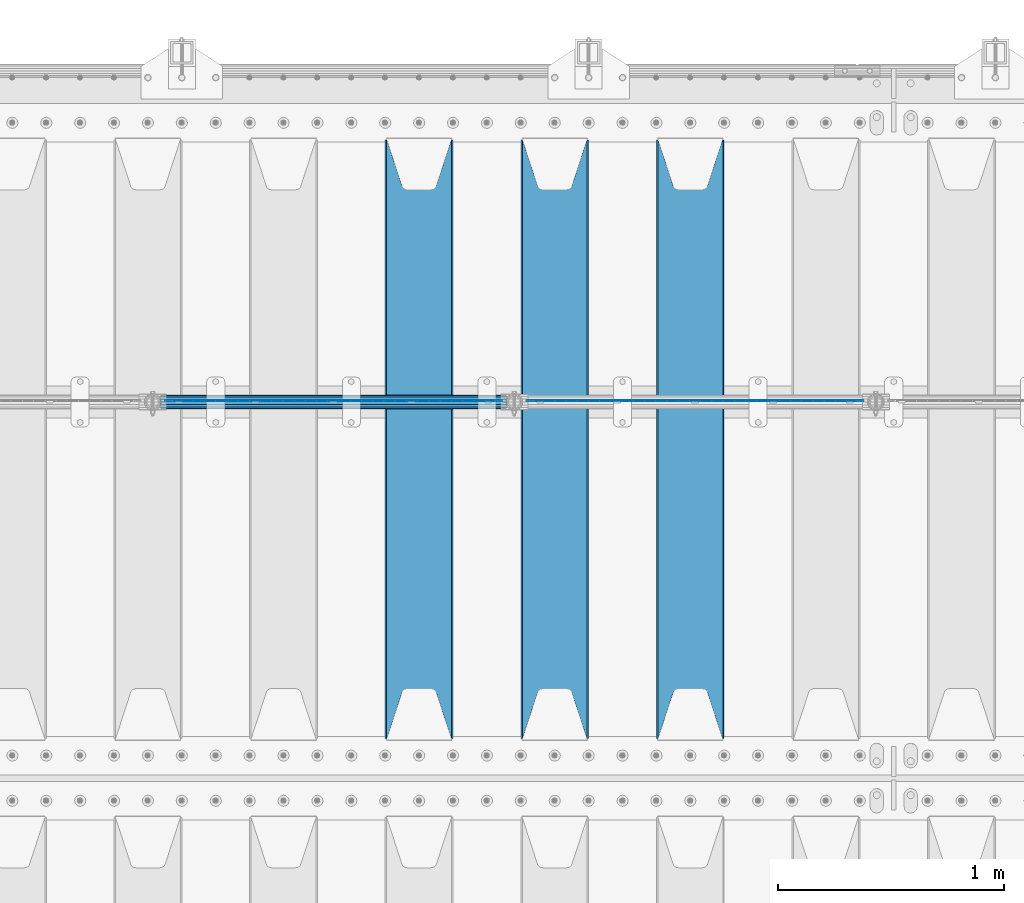
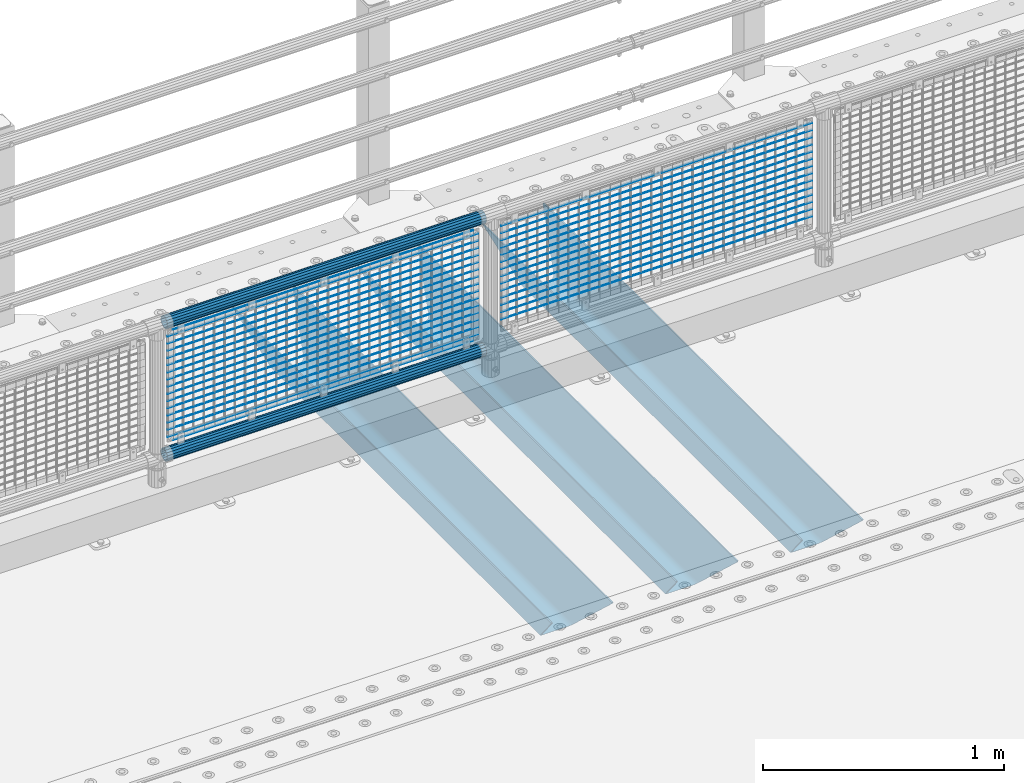
# One storey, part 95 of 208: 36 beams.
"""IFC2X3 building model written with IfcOpenShell, lengths in millimetres."""

import ifcopenshell
import ifcopenshell.guid

model = None  # the IFC model being written
_history = None  # IfcOwnerHistory: only IFC2X3 demands one
_inside = {}  # id of a spatial element -> (the spatial element, [elements in it])
_under = {}  # id of a project, library or spatial element -> (it, [spatial elements below it])
_declared = {}  # id of a project -> (the project, [libraries it declares])
_typed = {}  # id of a type object -> (the type object, [elements of that type])
_made_of = {}  # id of a material, layer set ... -> (it, [elements and type objects made of it])


def new_model(schema):
    """Start an empty IFC model of exactly this schema.

    Asked for "IFC4X3", IfcOpenShell would pick the latest addendum, in which some entities
    have other attributes; the version numbers below select the first issue.
    IFC2X3 requires an IfcOwnerHistory on every rooted entity: one is made here for all.
    """
    global model, _history
    if schema == "IFC4X3":
        model = ifcopenshell.file(schema_version=(4, 3, 0, 0))
    else:
        model = ifcopenshell.file(schema=schema)
    _inside.clear()
    _under.clear()
    _declared.clear()
    _typed.clear()
    _made_of.clear()
    _history = None
    if model.schema == "IFC2X3":
        org = make("IfcOrganization", Name="unknown")
        user = make(
            "IfcPersonAndOrganization",
            ThePerson=make("IfcPerson", FamilyName="unknown"),
            TheOrganization=org,
        )
        app = make(
            "IfcApplication",
            ApplicationDeveloper=org,
            Version="unknown",
            ApplicationFullName="unknown",
            ApplicationIdentifier="unknown",
        )
        _history = make(
            "IfcOwnerHistory",
            OwningUser=user,
            OwningApplication=app,
            ChangeAction="ADDED",
            CreationDate=0,
        )
    return model


def make(cls, **values):
    """One entity of the class cls with the attributes given. An attribute that is None is left unset."""
    return model.create_entity(
        cls, **{name: value for name, value in values.items() if value is not None}
    )


def rooted(cls, **values):
    """An entity with a GlobalId (a new one), such as an element, a storey or a relation."""
    return make(cls, GlobalId=ifcopenshell.guid.new(), OwnerHistory=_history, **values)


def si_unit(unit_type, name, prefix=None):
    """IfcSIUnit, for example si_unit("LENGTHUNIT", "METRE", prefix="MILLI")."""
    return make("IfcSIUnit", UnitType=unit_type, Prefix=prefix, Name=name)


def assignment(units):
    """IfcUnitAssignment: the units of a project."""
    return None if units is None else make("IfcUnitAssignment", Units=units)


def point(xyz):
    """IfcCartesianPoint."""
    return None if xyz is None else make("IfcCartesianPoint", Coordinates=xyz)


def direction(xyz):
    """IfcDirection."""
    return None if xyz is None else make("IfcDirection", DirectionRatios=xyz)


def frame(location, z_axis=None, x_axis=None):
    """IfcAxis2Placement3D, a coordinate frame: its origin and axes. An axis left out is left unset."""
    return make(
        "IfcAxis2Placement3D",
        Location=point(location),
        Axis=direction(z_axis),
        RefDirection=direction(x_axis),
    )


def origin_with_axes():
    """The frame at (0, 0, 0) with the z axis (0, 0, 1) and the x axis (1, 0, 0) written out."""
    return frame((0.0, 0.0, 0.0), z_axis=(0.0, 0.0, 1.0), x_axis=(1.0, 0.0, 0.0))


def place(relative_to, where):
    """IfcLocalPlacement: puts the frame where relative to a parent placement (None: the world)."""
    return make(
        "IfcLocalPlacement", PlacementRelTo=relative_to, RelativePlacement=where
    )


def context(
    kind, dimensions, precision=None, world=None, true_north=None, identifier=None
):
    """IfcGeometricRepresentationContext, for example the 3D "Model" context."""
    return make(
        "IfcGeometricRepresentationContext",
        ContextIdentifier=identifier,
        ContextType=kind,
        CoordinateSpaceDimension=dimensions,
        Precision=precision,
        WorldCoordinateSystem=world,
        TrueNorth=true_north,
    )


def subcontext(parent, identifier, kind, view, scale=None):
    """IfcGeometricRepresentationSubContext, for example "Body" below "Model"."""
    return make(
        "IfcGeometricRepresentationSubContext",
        ContextIdentifier=identifier,
        ContextType=kind,
        ParentContext=parent,
        TargetScale=scale,
        TargetView=view,
    )


def project(units=None, contexts=None):
    """IfcProject with its units and contexts."""
    return rooted(
        "IfcProject",
        Name="project",
        RepresentationContexts=contexts,
        UnitsInContext=assignment(units),
    )


def spatial(cls, under=None, at=None, **own):
    """A site, building, storey or space (cls), placed at a placement, below another one or the project."""
    s = rooted(cls, ObjectPlacement=at, **own)
    if under is not None:
        _under.setdefault(under.id(), (under, []))[1].append(s)
    return s


def faces_of(points, faces, orient=None, outer=None):
    """IfcFace entities. A face is a list of loops; a loop is a list of indices into points, from 0.

    orient and outer hold one flag for each loop. By default every Orientation is true, the
    first loop of a face is its IfcFaceOuterBound and the others are IfcFaceBound.
    """
    made = []
    for i, loops in enumerate(faces):
        bounds = []
        for j, loop in enumerate(loops):
            is_outer = j == 0 if outer is None else outer[i][j]
            bounds.append(
                make(
                    "IfcFaceOuterBound" if is_outer else "IfcFaceBound",
                    Bound=make("IfcPolyLoop", Polygon=[points[k] for k in loop]),
                    Orientation=True if orient is None else orient[i][j],
                )
            )
        made.append(make("IfcFace", Bounds=bounds))
    return made


def faceted_brep(points, faces, orient=None, outer=None, voids=None):
    """IfcFacetedBrep: a solid bounded by flat faces; with voids (closed shells), ...WithVoids."""
    shared = [point(p) for p in points]
    hull = make("IfcClosedShell", CfsFaces=faces_of(shared, faces, orient, outer))
    if voids is None:
        return make("IfcFacetedBrep", Outer=hull)
    return make(
        "IfcFacetedBrepWithVoids",
        Outer=hull,
        Voids=[
            make(cls, CfsFaces=faces_of(shared, fs, o, b)) for cls, fs, o, b in voids
        ],
    )


def shape(context_of_items, identifier, shape_type, items):
    """IfcShapeRepresentation: the items that make up one representation, for example the "Body"."""
    return make(
        "IfcShapeRepresentation",
        ContextOfItems=context_of_items,
        RepresentationIdentifier=identifier,
        RepresentationType=shape_type,
        Items=items,
    )


def material(Name=None, Category=None):
    """IfcMaterial."""
    return make("IfcMaterial", Name=Name, Category=Category)


def made_of(thing, what):
    """Note that an element or type object is made of a material, layer set ...; save() writes the relation."""
    if what is not None:
        _made_of.setdefault(what.id(), (what, []))[1].append(thing)
    return thing


def type_object(cls, material=None, **own):
    """A type object (cls), such as IfcWallType, which elements share."""
    return made_of(rooted(cls, **own), material)


def element(
    cls,
    number,
    at=None,
    inside=None,
    cuts=None,
    type_object=None,
    material=None,
    context=None,
    identifier="Body",
    shape_type=None,
    held_by="IfcProductDefinitionShape",
    body=None,
    shapes=None,
    **own,
):
    """One element of the class cls, such as IfcWall. Its Tag is "e" and its number.

    at: its placement. inside: the storey or other place that contains it. cuts: it is an
    opening in that element (IfcRelVoidsElement). A single representation is given by context,
    identifier, shape_type and body (its items); several are given by shapes. held_by: the class
    of the entity that holds the representations. save() writes the other relations.
    """
    e = rooted(cls, Tag="e%d" % number, ObjectPlacement=at, **own)
    if body is not None:
        shapes = [shape(context, identifier, shape_type, body)]
    if shapes is not None:
        e.Representation = make(held_by, Representations=shapes)
    if inside is not None:
        _inside.setdefault(inside.id(), (inside, []))[1].append(e)
    if cuts is not None:
        rooted(
            "IfcRelVoidsElement", RelatingBuildingElement=cuts, RelatedOpeningElement=e
        )
    if type_object is not None:
        _typed.setdefault(type_object.id(), (type_object, []))[1].append(e)
    return made_of(e, material)


def aggregate(whole, parts):
    """IfcRelAggregates: a whole, such as a stair, and the parts it consists of."""
    return rooted("IfcRelAggregates", RelatingObject=whole, RelatedObjects=parts)


def save(model, path):
    """Write the relations noted so far, then the file.

    IfcRelAggregates (storeys below a building ...), IfcRelContainedInSpatialStructure (elements
    in a storey), IfcRelDefinesByType, IfcRelAssociatesMaterial and IfcRelDeclares: one each for
    every whole, place, type object, material and project.
    """
    for whole, parts in _under.values():
        aggregate(whole, parts)
    for where, things in _inside.values():
        rooted(
            "IfcRelContainedInSpatialStructure",
            RelatedElements=things,
            RelatingStructure=where,
        )
    for kind, things in _typed.values():
        rooted("IfcRelDefinesByType", RelatedObjects=things, RelatingType=kind)
    for what, things in _made_of.values():
        rooted("IfcRelAssociatesMaterial", RelatedObjects=things, RelatingMaterial=what)
    for by, libraries in _declared.values():
        rooted("IfcRelDeclares", RelatingContext=by, RelatedDefinitions=libraries)
    model.write(path)


model = new_model("IFC2X3")

# Units and contexts
model_context = context("Model", 3, precision=1e-05, world=origin_with_axes())
body_context = subcontext(model_context, "Body", "Model", "MODEL_VIEW")
ifc_project = project(units=[si_unit("LENGTHUNIT", "METRE", prefix="MILLI"), si_unit("AREAUNIT", "SQUARE_METRE"), si_unit("VOLUMEUNIT", "CUBIC_METRE"), si_unit("MASSUNIT", "GRAM", prefix="KILO"), si_unit("TIMEUNIT", "SECOND"), si_unit("PLANEANGLEUNIT", "RADIAN"), si_unit("SOLIDANGLEUNIT", "STERADIAN"), si_unit("THERMODYNAMICTEMPERATUREUNIT", "DEGREE_CELSIUS"), si_unit("LUMINOUSINTENSITYUNIT", "LUMEN")], contexts=[model_context])

# Site, building, storey
site_placement = place(None, origin_with_axes())
site = spatial("IfcSite", under=ifc_project, at=site_placement, CompositionType="ELEMENT")
building_placement = place(site_placement, origin_with_axes())
building = spatial("IfcBuilding", under=site, at=building_placement, Name="Standard", CompositionType="ELEMENT")
storey_placement = place(building_placement, origin_with_axes())
storey = spatial("IfcBuildingStorey", under=building, at=storey_placement, Name="Undefined", CompositionType="ELEMENT", Elevation=0.0)

# Beams
ifc_material_1 = material(Name="STEEL/S355N")
beam_type_1 = type_object("IfcBeamType", PredefinedType="NOTDEFINED")
beam_1_placement = place(storey_placement, frame((-37850.0, 3175.0, -115.0), z_axis=(0.0, 0.0, 1.0), x_axis=(0.0, 1.0, 0.0)))
element("IfcBeam", 1, at=beam_1_placement, inside=storey, type_object=beam_type_1, material=ifc_material_1, context=body_context, shape_type="Brep", body=[
    faceted_brep([(0.0, 150.0, 115.0), (0.0, 143.689999999999, 115.0), (2650.00000000297, 143.689999999999, 115.0), (2650.00000000297, 150.0, 115.0), (2650.00000000297, 142.059565218402, 110.0000000031), (2650.00000000297, 148.369565218403, 110.0000000031), (2441.90079219208, -80.1103600731112, -98.0992078077845), (2437.7588105432, -77.5672621345584, -102.241189456673), (2434.06523489746, -74.4080125315522, -105.934765102404), (2430.91086095089, -70.710272125576, -109.089139048974), (2428.37322971128, -66.5649389910068, -111.626770288588), (2426.51472138055, -62.0739139532889, -113.485278619323), (2425.38102192091, -57.3475956567672, -114.618978078955), (2424.99999999987, -52.5021667386536, -115.0), (2424.99999999987, 52.5021667386536, -115.0), (2425.38102192091, 57.3475956567672, -114.618978078955), (2426.51472138055, 62.0739139532889, -113.485278619323), (2428.37322971128, 66.5649389910068, -111.626770288588), (2430.91086095089, 70.710272125576, -109.089139048974), (2434.06523489746, 74.4080125315522, -105.934765102404), (2437.7588105432, 77.5672621345584, -102.241189456673), (2441.90079219208, 80.1103600731112, -98.0992078077846), (2446.38936140511, 81.9747917625791, -93.6106385947584), (2448.24948500409, 76.2713538057251, -91.7505149957729), (2444.62967112262, 74.76777986261, -95.3703288772456), (2441.28936334126, 72.7168944282894, -98.710636658607), (2438.31067330438, 70.1691124903846, -101.689326695487), (2435.76682334747, 67.1870637758839, -104.233176652398), (2433.72034654133, 63.8440531834895, -106.279653458539), (2432.22154950041, 60.222258798236, -107.778450499454), (2431.30727574265, 56.4107117849089, -108.692724257221), (2430.99999999987, 52.5031078186876, -109.0), (2430.99999999987, -52.5031078186876, -109.0), (2431.30727574265, -56.4107117849089, -108.692724257221), (2432.22154950041, -60.222258798236, -107.778450499454), (2433.72034654133, -63.8440531834895, -106.279653458539), (2435.76682334747, -67.1870637758839, -104.233176652398), (2438.31067330438, -70.1691124903846, -101.689326695487), (2441.28936334126, -72.7168944282894, -98.7106366586071), (2444.62967112262, -74.76777986261, -95.3703288772457), (2448.24948500409, -76.2713538057251, -91.7505149957729), (2650.00000000297, -142.059565218402, 110.0000000031), (2650.00000000297, -148.369565218403, 110.0000000031), (2446.38936140511, -81.9747917625791, -93.6106385947584), (2650.00000000297, -143.689999999999, 115.0), (2650.00000000297, -150.0, 115.0), (0.0, -143.689999999999, 115.0), (0.0, -150.0, 115.0), (0.0, -148.369565218261, 110.000000002663), (203.610638597421, -81.9747917625791, -93.6106385947584), (208.099207810448, -80.1103600731112, -98.0992078077845), (212.241189459336, -77.5672621345584, -102.241189456673), (215.934765105067, -74.4080125315522, -105.934765102404), (219.089139051637, -70.710272125576, -109.089139048974), (221.626770291251, -66.5649389910068, -111.626770288588), (223.485278621986, -62.0739139532889, -113.485278619323), (224.618978081618, -57.3475956567672, -114.618978078955), (225.000000002663, -52.5021667386536, -115.0), (225.000000002663, 52.5021667386536, -115.0), (224.618978081618, 57.3475956567672, -114.618978078955), (223.485278621986, 62.0739139532889, -113.485278619323), (221.626770291251, 66.5649389910068, -111.626770288588), (219.089139051637, 70.710272125576, -109.089139048974), (215.934765105067, 74.4080125315522, -105.934765102404), (212.241189459336, 77.5672621345584, -102.241189456673), (208.099207810448, 80.1103600731112, -98.0992078077846), (203.610638597421, 81.9747917625791, -93.6106385947584), (0.0, 148.369565218261, 110.000000002663), (0.0, 142.05956521826, 110.000000002663), (201.750514998436, 76.2713538057251, -91.7505149957729), (205.370328879908, 74.76777986261, -95.3703288772456), (208.71063666127, 72.7168944282894, -98.710636658607), (211.68932669815, 70.1691124903846, -101.689326695487), (214.233176655061, 67.1870637758839, -104.233176652398), (216.279653461202, 63.8440531834895, -106.279653458539), (217.778450502116, 60.222258798236, -107.778450499454), (218.692724259884, 56.4107117849089, -108.692724257221), (219.000000002663, 52.5031078186876, -109.0), (219.000000002663, -52.5031078186876, -109.0), (218.692724259884, -56.4107117849089, -108.692724257221), (217.778450502116, -60.222258798236, -107.778450499454), (216.279653461202, -63.8440531834895, -106.279653458539), (214.233176655061, -67.1870637758839, -104.233176652398), (211.68932669815, -70.1691124903846, -101.689326695487), (208.71063666127, -72.7168944282894, -98.7106366586071), (205.370328879908, -74.76777986261, -95.3703288772457), (201.750514998436, -76.2713538057251, -91.7505149957729), (0.0, -142.05956521826, 110.000000002663)], [[[0, 1, 2, 3]], [[3, 2, 4, 5]], [[6, 7, 8, 9, 10, 11, 12, 13, 14, 15, 16, 17, 18, 19, 20, 21, 22, 5, 4, 23, 24, 25, 26, 27, 28, 29, 30, 31, 32, 33, 34, 35, 36, 37, 38, 39, 40, 41, 42, 43]], [[44, 45, 42, 41]], [[46, 47, 45, 44]], [[43, 42, 45, 47, 48, 49]], [[6, 43, 49, 50]], [[7, 6, 50, 51]], [[8, 7, 51, 52]], [[9, 8, 52, 53]], [[10, 9, 53, 54]], [[11, 10, 54, 55]], [[12, 11, 55, 56]], [[13, 12, 56, 57]], [[14, 13, 57, 58]], [[15, 14, 58, 59]], [[16, 15, 59, 60]], [[17, 16, 60, 61]], [[18, 17, 61, 62]], [[19, 18, 62, 63]], [[20, 19, 63, 64]], [[21, 20, 64, 65]], [[22, 21, 65, 66]], [[0, 3, 5, 22, 66, 67]], [[1, 0, 67, 68]], [[23, 4, 2, 1, 68, 69]], [[24, 23, 69, 70]], [[25, 24, 70, 71]], [[26, 25, 71, 72]], [[27, 26, 72, 73]], [[28, 27, 73, 74]], [[29, 28, 74, 75]], [[30, 29, 75, 76]], [[31, 30, 76, 77]], [[32, 31, 77, 78]], [[33, 32, 78, 79]], [[34, 33, 79, 80]], [[35, 34, 80, 81]], [[36, 35, 81, 82]], [[37, 36, 82, 83]], [[38, 37, 83, 84]], [[39, 38, 84, 85]], [[40, 39, 85, 86]], [[46, 44, 41, 40, 86, 87]], [[47, 46, 87, 48]], [[86, 85, 84, 83, 82, 81, 80, 79, 78, 77, 76, 75, 74, 73, 72, 71, 70, 69, 68, 67, 66, 65, 64, 63, 62, 61, 60, 59, 58, 57, 56, 55, 54, 53, 52, 51, 50, 49, 48, 87]]]),
])
beam_2_placement = place(storey_placement, frame((-38450.0, 3175.0, -115.0), z_axis=(0.0, 0.0, 1.0), x_axis=(0.0, 1.0, 0.0)))
element("IfcBeam", 2, at=beam_2_placement, inside=storey, type_object=beam_type_1, material=ifc_material_1, context=body_context, shape_type="Brep", body=[
    faceted_brep([(0.0, 150.0, 115.0), (0.0, 143.689999999999, 115.0), (2650.00000000297, 143.689999999999, 115.0), (2650.00000000297, 150.0, 115.0), (2650.00000000297, 142.059565218402, 110.0000000031), (2650.00000000297, 148.369565218403, 110.0000000031), (2441.90079219208, -80.1103600731112, -98.0992078077845), (2437.7588105432, -77.5672621345584, -102.241189456673), (2434.06523489746, -74.4080125315522, -105.934765102404), (2430.91086095089, -70.710272125576, -109.089139048974), (2428.37322971128, -66.5649389910068, -111.626770288588), (2426.51472138055, -62.0739139532889, -113.485278619323), (2425.38102192091, -57.3475956567672, -114.618978078955), (2424.99999999987, -52.5021667386536, -115.0), (2424.99999999987, 52.5021667386536, -115.0), (2425.38102192091, 57.3475956567672, -114.618978078955), (2426.51472138055, 62.0739139532889, -113.485278619323), (2428.37322971128, 66.5649389910068, -111.626770288588), (2430.91086095089, 70.710272125576, -109.089139048974), (2434.06523489746, 74.4080125315522, -105.934765102404), (2437.7588105432, 77.5672621345584, -102.241189456673), (2441.90079219208, 80.1103600731112, -98.0992078077846), (2446.38936140511, 81.9747917625791, -93.6106385947584), (2448.24948500409, 76.2713538057251, -91.7505149957729), (2444.62967112262, 74.76777986261, -95.3703288772456), (2441.28936334126, 72.7168944282894, -98.710636658607), (2438.31067330438, 70.1691124903846, -101.689326695487), (2435.76682334747, 67.1870637758839, -104.233176652398), (2433.72034654133, 63.8440531834895, -106.279653458539), (2432.22154950041, 60.222258798236, -107.778450499454), (2431.30727574265, 56.4107117849089, -108.692724257221), (2430.99999999987, 52.5031078186876, -109.0), (2430.99999999987, -52.5031078186876, -109.0), (2431.30727574265, -56.4107117849089, -108.692724257221), (2432.22154950041, -60.222258798236, -107.778450499454), (2433.72034654133, -63.8440531834895, -106.279653458539), (2435.76682334747, -67.1870637758839, -104.233176652398), (2438.31067330438, -70.1691124903846, -101.689326695487), (2441.28936334126, -72.7168944282894, -98.7106366586071), (2444.62967112262, -74.76777986261, -95.3703288772457), (2448.24948500409, -76.2713538057251, -91.7505149957729), (2650.00000000297, -142.059565218402, 110.0000000031), (2650.00000000297, -148.369565218403, 110.0000000031), (2446.38936140511, -81.9747917625791, -93.6106385947584), (2650.00000000297, -143.689999999999, 115.0), (2650.00000000297, -150.0, 115.0), (0.0, -143.689999999999, 115.0), (0.0, -150.0, 115.0), (0.0, -148.369565218261, 110.000000002663), (203.610638597421, -81.9747917625791, -93.6106385947584), (208.099207810448, -80.1103600731112, -98.0992078077845), (212.241189459336, -77.5672621345584, -102.241189456673), (215.934765105067, -74.4080125315522, -105.934765102404), (219.089139051637, -70.710272125576, -109.089139048974), (221.626770291251, -66.5649389910068, -111.626770288588), (223.485278621986, -62.0739139532889, -113.485278619323), (224.618978081618, -57.3475956567672, -114.618978078955), (225.000000002663, -52.5021667386536, -115.0), (225.000000002663, 52.5021667386536, -115.0), (224.618978081618, 57.3475956567672, -114.618978078955), (223.485278621986, 62.0739139532889, -113.485278619323), (221.626770291251, 66.5649389910068, -111.626770288588), (219.089139051637, 70.710272125576, -109.089139048974), (215.934765105067, 74.4080125315522, -105.934765102404), (212.241189459336, 77.5672621345584, -102.241189456673), (208.099207810448, 80.1103600731112, -98.0992078077846), (203.610638597421, 81.9747917625791, -93.6106385947584), (0.0, 148.369565218261, 110.000000002663), (0.0, 142.05956521826, 110.000000002663), (201.750514998436, 76.2713538057251, -91.7505149957729), (205.370328879908, 74.76777986261, -95.3703288772456), (208.71063666127, 72.7168944282894, -98.710636658607), (211.68932669815, 70.1691124903846, -101.689326695487), (214.233176655061, 67.1870637758839, -104.233176652398), (216.279653461202, 63.8440531834895, -106.279653458539), (217.778450502116, 60.222258798236, -107.778450499454), (218.692724259884, 56.4107117849089, -108.692724257221), (219.000000002663, 52.5031078186876, -109.0), (219.000000002663, -52.5031078186876, -109.0), (218.692724259884, -56.4107117849089, -108.692724257221), (217.778450502116, -60.222258798236, -107.778450499454), (216.279653461202, -63.8440531834895, -106.279653458539), (214.233176655061, -67.1870637758839, -104.233176652398), (211.68932669815, -70.1691124903846, -101.689326695487), (208.71063666127, -72.7168944282894, -98.7106366586071), (205.370328879908, -74.76777986261, -95.3703288772457), (201.750514998436, -76.2713538057251, -91.7505149957729), (0.0, -142.05956521826, 110.000000002663)], [[[0, 1, 2, 3]], [[3, 2, 4, 5]], [[6, 7, 8, 9, 10, 11, 12, 13, 14, 15, 16, 17, 18, 19, 20, 21, 22, 5, 4, 23, 24, 25, 26, 27, 28, 29, 30, 31, 32, 33, 34, 35, 36, 37, 38, 39, 40, 41, 42, 43]], [[44, 45, 42, 41]], [[46, 47, 45, 44]], [[43, 42, 45, 47, 48, 49]], [[6, 43, 49, 50]], [[7, 6, 50, 51]], [[8, 7, 51, 52]], [[9, 8, 52, 53]], [[10, 9, 53, 54]], [[11, 10, 54, 55]], [[12, 11, 55, 56]], [[13, 12, 56, 57]], [[14, 13, 57, 58]], [[15, 14, 58, 59]], [[16, 15, 59, 60]], [[17, 16, 60, 61]], [[18, 17, 61, 62]], [[19, 18, 62, 63]], [[20, 19, 63, 64]], [[21, 20, 64, 65]], [[22, 21, 65, 66]], [[0, 3, 5, 22, 66, 67]], [[1, 0, 67, 68]], [[23, 4, 2, 1, 68, 69]], [[24, 23, 69, 70]], [[25, 24, 70, 71]], [[26, 25, 71, 72]], [[27, 26, 72, 73]], [[28, 27, 73, 74]], [[29, 28, 74, 75]], [[30, 29, 75, 76]], [[31, 30, 76, 77]], [[32, 31, 77, 78]], [[33, 32, 78, 79]], [[34, 33, 79, 80]], [[35, 34, 80, 81]], [[36, 35, 81, 82]], [[37, 36, 82, 83]], [[38, 37, 83, 84]], [[39, 38, 84, 85]], [[40, 39, 85, 86]], [[46, 44, 41, 40, 86, 87]], [[47, 46, 87, 48]], [[86, 85, 84, 83, 82, 81, 80, 79, 78, 77, 76, 75, 74, 73, 72, 71, 70, 69, 68, 67, 66, 65, 64, 63, 62, 61, 60, 59, 58, 57, 56, 55, 54, 53, 52, 51, 50, 49, 48, 87]]]),
])
beam_3_placement = place(storey_placement, frame((-39050.0, 3175.0, -115.0), z_axis=(0.0, 0.0, 1.0), x_axis=(0.0, 1.0, 0.0)))
element("IfcBeam", 3, at=beam_3_placement, inside=storey, type_object=beam_type_1, material=ifc_material_1, context=body_context, shape_type="Brep", body=[
    faceted_brep([(0.0, 150.0, 115.0), (0.0, 143.689999999999, 115.0), (2650.00000000297, 143.689999999999, 115.0), (2650.00000000297, 150.0, 115.0), (2650.00000000297, 142.059565218402, 110.0000000031), (2650.00000000297, 148.369565218403, 110.0000000031), (2441.90079219208, -80.1103600731112, -98.0992078077845), (2437.7588105432, -77.5672621345584, -102.241189456673), (2434.06523489746, -74.4080125315522, -105.934765102404), (2430.91086095089, -70.710272125576, -109.089139048974), (2428.37322971128, -66.5649389910068, -111.626770288588), (2426.51472138055, -62.0739139532889, -113.485278619323), (2425.38102192091, -57.3475956567672, -114.618978078955), (2424.99999999987, -52.5021667386536, -115.0), (2424.99999999987, 52.5021667386536, -115.0), (2425.38102192091, 57.3475956567672, -114.618978078955), (2426.51472138055, 62.0739139532889, -113.485278619323), (2428.37322971128, 66.5649389910068, -111.626770288588), (2430.91086095089, 70.710272125576, -109.089139048974), (2434.06523489746, 74.4080125315522, -105.934765102404), (2437.7588105432, 77.5672621345584, -102.241189456673), (2441.90079219208, 80.1103600731112, -98.0992078077846), (2446.38936140511, 81.9747917625791, -93.6106385947584), (2448.24948500409, 76.2713538057251, -91.7505149957729), (2444.62967112262, 74.76777986261, -95.3703288772456), (2441.28936334126, 72.7168944282894, -98.710636658607), (2438.31067330438, 70.1691124903846, -101.689326695487), (2435.76682334747, 67.1870637758839, -104.233176652398), (2433.72034654133, 63.8440531834895, -106.279653458539), (2432.22154950041, 60.222258798236, -107.778450499454), (2431.30727574265, 56.4107117849089, -108.692724257221), (2430.99999999987, 52.5031078186876, -109.0), (2430.99999999987, -52.5031078186876, -109.0), (2431.30727574265, -56.4107117849089, -108.692724257221), (2432.22154950041, -60.222258798236, -107.778450499454), (2433.72034654133, -63.8440531834895, -106.279653458539), (2435.76682334747, -67.1870637758839, -104.233176652398), (2438.31067330438, -70.1691124903846, -101.689326695487), (2441.28936334126, -72.7168944282894, -98.7106366586071), (2444.62967112262, -74.76777986261, -95.3703288772457), (2448.24948500409, -76.2713538057251, -91.7505149957729), (2650.00000000297, -142.059565218402, 110.0000000031), (2650.00000000297, -148.369565218403, 110.0000000031), (2446.38936140511, -81.9747917625791, -93.6106385947584), (2650.00000000297, -143.689999999999, 115.0), (2650.00000000297, -150.0, 115.0), (0.0, -143.689999999999, 115.0), (0.0, -150.0, 115.0), (0.0, -148.369565218261, 110.000000002663), (203.610638597421, -81.9747917625791, -93.6106385947584), (208.099207810448, -80.1103600731112, -98.0992078077845), (212.241189459336, -77.5672621345584, -102.241189456673), (215.934765105067, -74.4080125315522, -105.934765102404), (219.089139051637, -70.710272125576, -109.089139048974), (221.626770291251, -66.5649389910068, -111.626770288588), (223.485278621986, -62.0739139532889, -113.485278619323), (224.618978081618, -57.3475956567672, -114.618978078955), (225.000000002663, -52.5021667386536, -115.0), (225.000000002663, 52.5021667386536, -115.0), (224.618978081618, 57.3475956567672, -114.618978078955), (223.485278621986, 62.0739139532889, -113.485278619323), (221.626770291251, 66.5649389910068, -111.626770288588), (219.089139051637, 70.710272125576, -109.089139048974), (215.934765105067, 74.4080125315522, -105.934765102404), (212.241189459336, 77.5672621345584, -102.241189456673), (208.099207810448, 80.1103600731112, -98.0992078077846), (203.610638597421, 81.9747917625791, -93.6106385947584), (0.0, 148.369565218261, 110.000000002663), (0.0, 142.05956521826, 110.000000002663), (201.750514998436, 76.2713538057251, -91.7505149957729), (205.370328879908, 74.76777986261, -95.3703288772456), (208.71063666127, 72.7168944282894, -98.710636658607), (211.68932669815, 70.1691124903846, -101.689326695487), (214.233176655061, 67.1870637758839, -104.233176652398), (216.279653461202, 63.8440531834895, -106.279653458539), (217.778450502116, 60.222258798236, -107.778450499454), (218.692724259884, 56.4107117849089, -108.692724257221), (219.000000002663, 52.5031078186876, -109.0), (219.000000002663, -52.5031078186876, -109.0), (218.692724259884, -56.4107117849089, -108.692724257221), (217.778450502116, -60.222258798236, -107.778450499454), (216.279653461202, -63.8440531834895, -106.279653458539), (214.233176655061, -67.1870637758839, -104.233176652398), (211.68932669815, -70.1691124903846, -101.689326695487), (208.71063666127, -72.7168944282894, -98.7106366586071), (205.370328879908, -74.76777986261, -95.3703288772457), (201.750514998436, -76.2713538057251, -91.7505149957729), (0.0, -142.05956521826, 110.000000002663)], [[[0, 1, 2, 3]], [[3, 2, 4, 5]], [[6, 7, 8, 9, 10, 11, 12, 13, 14, 15, 16, 17, 18, 19, 20, 21, 22, 5, 4, 23, 24, 25, 26, 27, 28, 29, 30, 31, 32, 33, 34, 35, 36, 37, 38, 39, 40, 41, 42, 43]], [[44, 45, 42, 41]], [[46, 47, 45, 44]], [[43, 42, 45, 47, 48, 49]], [[6, 43, 49, 50]], [[7, 6, 50, 51]], [[8, 7, 51, 52]], [[9, 8, 52, 53]], [[10, 9, 53, 54]], [[11, 10, 54, 55]], [[12, 11, 55, 56]], [[13, 12, 56, 57]], [[14, 13, 57, 58]], [[15, 14, 58, 59]], [[16, 15, 59, 60]], [[17, 16, 60, 61]], [[18, 17, 61, 62]], [[19, 18, 62, 63]], [[20, 19, 63, 64]], [[21, 20, 64, 65]], [[22, 21, 65, 66]], [[0, 3, 5, 22, 66, 67]], [[1, 0, 67, 68]], [[23, 4, 2, 1, 68, 69]], [[24, 23, 69, 70]], [[25, 24, 70, 71]], [[26, 25, 71, 72]], [[27, 26, 72, 73]], [[28, 27, 73, 74]], [[29, 28, 74, 75]], [[30, 29, 75, 76]], [[31, 30, 76, 77]], [[32, 31, 77, 78]], [[33, 32, 78, 79]], [[34, 33, 79, 80]], [[35, 34, 80, 81]], [[36, 35, 81, 82]], [[37, 36, 82, 83]], [[38, 37, 83, 84]], [[39, 38, 84, 85]], [[40, 39, 85, 86]], [[46, 44, 41, 40, 86, 87]], [[47, 46, 87, 48]], [[86, 85, 84, 83, 82, 81, 80, 79, 78, 77, 76, 75, 74, 73, 72, 71, 70, 69, 68, 67, 66, 65, 64, 63, 62, 61, 60, 59, 58, 57, 56, 55, 54, 53, 52, 51, 50, 49, 48, 87]]]),
])
ifc_material_2 = material(Name="Misc_Undefined")
beam_type_2 = type_object("IfcBeamType", Name="D3", PredefinedType="NOTDEFINED")
for number, where, z_axis, x_axis in (
    (4, (-38574.0, 4670.5, 851.597), (0.0, 0.0, 1.0), (1.0, 0.0, 0.0)),
    (5, (-38574.0, 4670.5, 669.452), (0.0, 0.0, 1.0), (1.0, 0.0, 0.0)),
    (6, (-38574.0, 4670.5, 523.736), (0.0, 0.0, 1.0), (1.0, 0.0, 0.0)),
    (7, (-38574.0, 4670.5, 487.307), (0.0, 0.0, 1.0), (1.0, 0.0, 0.0)),
    (8, (-38574.0, 4670.5, 705.881), (0.0, 0.0, 1.0), (1.0, 0.0, 0.0)),
    (9, (-38574.0, 4670.5, 596.594000000001), (0.0, 0.0, 1.0), (1.0, 0.0, 0.0)),
    (10, (-38574.0, 4670.5, 450.878), (0.0, 0.0, 1.0), (1.0, 0.0, 0.0)),
    (11, (-38574.0, 4670.5, 815.168), (0.0, 0.0, 1.0), (1.0, 0.0, 0.0)),
    (12, (-38574.0, 4670.5, 888.026), (0.0, 0.0, 1.0), (1.0, 0.0, 0.0)),
    (13, (-38574.0, 4670.5, 778.739), (0.0, 0.0, 1.0), (1.0, 0.0, 0.0)),
    (14, (-38574.0, 4670.5, 742.31), (0.0, 0.0, 1.0), (1.0, 0.0, 0.0)),
    (15, (-38574.0, 4670.5, 633.023), (0.0, 0.0, 1.0), (1.0, 0.0, 0.0)),
    (16, (-38574.0, 4670.5, 560.165), (0.0, 0.0, 1.0), (1.0, 0.0, 0.0)),
    (17, (-38574.0, 4670.5, 414.449), (0.0, 0.0, 1.0), (1.0, 0.0, 0.0)),
    (18, (-40174.0, 4670.5, 851.596999999999), (0.0, 0.0, 1.0), (1.0, 0.0, 0.0)),
    (19, (-40174.0, 4670.5, 669.452), (0.0, 0.0, 1.0), (1.0, 0.0, 0.0)),
    (20, (-40174.0, 4670.5, 523.736), (0.0, 0.0, 1.0), (1.0, 0.0, 0.0)),
    (21, (-40174.0, 4670.5, 487.307), (0.0, 0.0, 1.0), (1.0, 0.0, 0.0)),
    (22, (-40174.0, 4670.5, 705.881), (0.0, 0.0, 1.0), (1.0, 0.0, 0.0)),
    (23, (-40174.0, 4670.5, 596.594), (0.0, 0.0, 1.0), (1.0, 0.0, 0.0)),
    (24, (-40174.0, 4670.5, 450.878), (0.0, 0.0, 1.0), (1.0, 0.0, 0.0)),
    (25, (-40174.0, 4670.5, 815.167999999999), (0.0, 0.0, 1.0), (1.0, 0.0, 0.0)),
    (26, (-40174.0, 4670.5, 888.025999999999), (0.0, 0.0, 1.0), (1.0, 0.0, 0.0)),
    (27, (-40174.0, 4670.5, 778.738999999999), (0.0, 0.0, 1.0), (1.0, 0.0, 0.0)),
    (28, (-40174.0, 4670.5, 742.309999999999), (0.0, 0.0, 1.0), (1.0, 0.0, 0.0)),
    (29, (-40174.0, 4670.5, 633.023), (0.0, 0.0, 1.0), (1.0, 0.0, 0.0)),
    (30, (-40174.0, 4670.5, 560.165), (0.0, 0.0, 1.0), (1.0, 0.0, 0.0)),
    (31, (-40174.0, 4670.5, 414.449), (0.0, 0.0, 1.0), (1.0, 0.0, 0.0)),
):
    element("IfcBeam", number, at=place(storey_placement, frame(where, z_axis=z_axis, x_axis=x_axis)), inside=storey, type_object=beam_type_2, material=ifc_material_2, ObjectType="D3", context=body_context, shape_type="Brep", body=[
        faceted_brep([(0.0, -1.49999999999909, 3.63797880709171e-12), (-7.27595761418343e-12, -0.749999999999091, -1.29903810567669), (1490.0, -0.75, -1.29903810567669), (1490.0, -1.5, 0.0), (-3.63797880709171e-12, 0.750000000000909, -1.29903810567669), (1490.0, 0.75, -1.29903810567669), (0.0, 1.50000000000182, 3.63797880709171e-12), (1490.0, 1.5, 0.0), (-3.63797880709171e-12, 0.750000000000909, 1.29903810567669), (1490.0, 0.75, 1.29903810567669), (-7.27595761418343e-12, -0.749999999999091, 1.29903810567669), (1490.0, -0.75, 1.29903810567669)], [[[0, 1, 2, 3]], [[1, 4, 5, 2]], [[4, 6, 7, 5]], [[6, 8, 9, 7]], [[8, 10, 11, 9]], [[10, 0, 3, 11]], [[5, 7, 9, 11, 3, 2]], [[10, 8, 6, 4, 1, 0]]]),
    ])
beam_4_placement = place(storey_placement, frame((-40149.0, 4670.5, 353.02), z_axis=(0.0, 0.0, 1.0), x_axis=(1.0, 0.0, 0.0)))
element("IfcBeam", 32, at=beam_4_placement, inside=storey, type_object=beam_type_2, material=ifc_material_2, ObjectType="D3", context=body_context, shape_type="Brep", body=[
    faceted_brep([(0.0, -1.49999999999909, 3.63797880709171e-12), (-7.27595761418343e-12, -0.749999999999091, -1.29903810567669), (1440.0, -0.75, -1.29903810567669), (1440.0, -1.5, 0.0), (-3.63797880709171e-12, 0.750000000000909, -1.29903810567669), (1440.0, 0.75, -1.29903810567663), (0.0, 1.50000000000182, 3.63797880709171e-12), (1440.0, 1.5, 0.0), (-3.63797880709171e-12, 0.750000000000909, 1.29903810567669), (1440.0, 0.75, 1.29903810567669), (-7.27595761418343e-12, -0.749999999999091, 1.29903810567669), (1440.0, -0.75, 1.29903810567669)], [[[0, 1, 2, 3]], [[1, 4, 5, 2]], [[4, 6, 7, 5]], [[6, 8, 9, 7]], [[8, 10, 11, 9]], [[10, 0, 3, 11]], [[5, 7, 9, 11, 3, 2]], [[10, 8, 6, 4, 1, 0]]]),
])
beam_5_placement = place(storey_placement, frame((-40174.0, 4670.5, 378.02), z_axis=(0.0, 0.0, 1.0), x_axis=(1.0, 0.0, 0.0)))
element("IfcBeam", 33, at=beam_5_placement, inside=storey, type_object=beam_type_2, material=ifc_material_2, ObjectType="D3", context=body_context, shape_type="Brep", body=[
    faceted_brep([(0.0, -1.49999999999909, 3.63797880709171e-12), (-7.27595761418343e-12, -0.749999999999091, -1.29903810567669), (1490.0, -0.75, -1.29903810567669), (1490.0, -1.5, 0.0), (-3.63797880709171e-12, 0.750000000000909, -1.29903810567669), (1490.0, 0.75, -1.29903810567669), (0.0, 1.50000000000182, 3.63797880709171e-12), (1490.0, 1.5, 0.0), (-3.63797880709171e-12, 0.750000000000909, 1.29903810567669), (1490.0, 0.75, 1.29903810567669), (-7.27595761418343e-12, -0.749999999999091, 1.29903810567669), (1490.0, -0.75, 1.29903810567669)], [[[0, 1, 2, 3]], [[1, 4, 5, 2]], [[4, 6, 7, 5]], [[6, 8, 9, 7]], [[8, 10, 11, 9]], [[10, 0, 3, 11]], [[5, 7, 9, 11, 3, 2]], [[10, 8, 6, 4, 1, 0]]]),
])
beam_6_placement = place(storey_placement, frame((-40149.0, 4670.5, 913.02), z_axis=(0.0, 0.0, 1.0), x_axis=(1.0, 0.0, 0.0)))
element("IfcBeam", 34, at=beam_6_placement, inside=storey, type_object=beam_type_2, material=ifc_material_2, ObjectType="D3", context=body_context, shape_type="Brep", body=[
    faceted_brep([(0.0, -1.49999999999909, 3.63797880709171e-12), (-7.27595761418343e-12, -0.749999999999091, -1.29903810567669), (1440.0, -0.75, -1.29903810567669), (1440.0, -1.5, 0.0), (-3.63797880709171e-12, 0.750000000000909, -1.29903810567669), (1440.0, 0.75, -1.29903810567663), (0.0, 1.50000000000182, 3.63797880709171e-12), (1440.0, 1.5, 0.0), (-3.63797880709171e-12, 0.750000000000909, 1.29903810567669), (1440.0, 0.75, 1.29903810567669), (-7.27595761418343e-12, -0.749999999999091, 1.29903810567669), (1440.0, -0.75, 1.29903810567669)], [[[0, 1, 2, 3]], [[1, 4, 5, 2]], [[4, 6, 7, 5]], [[6, 8, 9, 7]], [[8, 10, 11, 9]], [[10, 0, 3, 11]], [[5, 7, 9, 11, 3, 2]], [[10, 8, 6, 4, 1, 0]]]),
])
ifc_material_3 = material()
beam_type_3 = type_object("IfcBeamType", PredefinedType="NOTDEFINED")
beam_7_placement = place(storey_placement, frame((-40194.15, 4664.5, 298.170000000001), z_axis=(0.0, 0.0, 1.0), x_axis=(1.0, 0.0, 0.0)))
element("IfcBeam", 35, at=beam_7_placement, inside=storey, type_object=beam_type_3, material=ifc_material_3, context=body_context, shape_type="Brep", body=[
    faceted_brep([(0.0, -25.3500000000004, 0.0), (0.0, -23.4203461491616, 9.70102501045403), (1530.0, -23.4203461491616, 9.70102501045506), (1530.0, -25.3500000000004, 0.0), (0.0, -17.9251569030794, 17.9251569030785), (1530.0, -17.9251569030794, 17.925156903079), (0.0, -9.70102501045494, 23.4203461491597), (1530.0, -9.70102501045494, 23.4203461491611), (0.0, 0.0, 25.3499999999985), (1530.0, 0.0, 25.35), (0.0, 9.70102501045494, 23.4203461491597), (1530.0, 9.70102501045494, 23.4203461491611), (0.0, 17.9251569030794, 17.9251569030785), (1530.0, 17.9251569030794, 17.925156903079), (0.0, 23.4203461491616, 9.70102501045403), (1530.0, 23.4203461491616, 9.701025010455), (0.0, 25.3500000000004, 0.0), (1530.0, 25.3500000000004, 0.0), (0.0, 23.4203461491616, -9.70102501045403), (1530.0, 23.4203461491616, -9.70102501045506), (0.0, 17.9251569030794, -17.9251569030785), (1530.0, 17.9251569030794, -17.925156903079), (0.0, 9.70102501045494, -23.4203461491597), (1530.0, 9.70102501045494, -23.4203461491611), (0.0, 0.0, -25.3499999999985), (1530.0, 0.0, -25.35), (0.0, -9.70102501045494, -23.4203461491597), (1530.0, -9.70102501045494, -23.4203461491611), (0.0, -17.9251569030794, -17.9251569030785), (1530.0, -17.9251569030794, -17.925156903079), (0.0, -23.4203461491616, -9.70102501045403), (1530.0, -23.4203461491616, -9.701025010455), (0.0, -30.1499999999996, 0.0), (0.0, -27.8549679052148, -11.5379054858058), (1530.0, -27.8549679052148, -11.5379054858075), (1530.0, -30.1499999999996, 0.0), (0.0, -21.3192694527743, -21.3192694527752), (1530.0, -21.3192694527743, -21.3192694527744), (0.0, -11.5379054858076, -27.8549679052157), (1530.0, -11.5379054858076, -27.8549679052153), (0.0, 0.0, -30.1500000000015), (1530.0, 0.0, -30.15), (0.0, 11.5379054858076, -27.8549679052157), (1530.0, 11.5379054858076, -27.8549679052153), (0.0, 21.3192694527743, -21.3192694527752), (1530.0, 21.3192694527743, -21.3192694527744), (0.0, 27.8549679052157, -11.5379054858058), (1530.0, 27.8549679052157, -11.5379054858075), (0.0, 30.1499999999996, 0.0), (1530.0, 30.1499999999996, 0.0), (0.0, 27.8549679052157, 11.5379054858058), (1530.0, 27.8549679052157, 11.5379054858075), (0.0, 21.3192694527743, 21.3192694527752), (1530.0, 21.3192694527743, 21.3192694527744), (0.0, 11.5379054858076, 27.8549679052157), (1530.0, 11.5379054858076, 27.8549679052153), (0.0, 0.0, 30.1500000000015), (1530.0, 0.0, 30.15), (0.0, -11.5379054858076, 27.8549679052157), (1530.0, -11.5379054858076, 27.8549679052153), (0.0, -21.3192694527743, 21.3192694527752), (1530.0, -21.3192694527743, 21.3192694527744), (0.0, -27.8549679052157, 11.5379054858058), (1530.0, -27.8549679052157, 11.5379054858075)], [[[0, 1, 2, 3]], [[1, 4, 5, 2]], [[4, 6, 7, 5]], [[6, 8, 9, 7]], [[8, 10, 11, 9]], [[10, 12, 13, 11]], [[12, 14, 15, 13]], [[14, 16, 17, 15]], [[16, 18, 19, 17]], [[18, 20, 21, 19]], [[20, 22, 23, 21]], [[22, 24, 25, 23]], [[24, 26, 27, 25]], [[26, 28, 29, 27]], [[28, 30, 31, 29]], [[30, 0, 3, 31]], [[32, 33, 34, 35]], [[33, 36, 37, 34]], [[36, 38, 39, 37]], [[38, 40, 41, 39]], [[40, 42, 43, 41]], [[42, 44, 45, 43]], [[44, 46, 47, 45]], [[46, 48, 49, 47]], [[48, 50, 51, 49]], [[50, 52, 53, 51]], [[52, 54, 55, 53]], [[54, 56, 57, 55]], [[56, 58, 59, 57]], [[58, 60, 61, 59]], [[60, 62, 63, 61]], [[62, 32, 35, 63]], [[37, 39, 41, 43, 45, 47, 49, 51, 53, 55, 57, 59, 61, 63, 35, 34], [5, 7, 9, 11, 13, 15, 17, 19, 21, 23, 25, 27, 29, 31, 3, 2]], [[62, 60, 58, 56, 54, 52, 50, 48, 46, 44, 42, 40, 38, 36, 33, 32], [30, 28, 26, 24, 22, 20, 18, 16, 14, 12, 10, 8, 6, 4, 1, 0]]]),
])
beam_8_placement = place(storey_placement, frame((-40194.15, 4664.5, 969.849999999999), z_axis=(0.0, 0.0, 1.0), x_axis=(1.0, 0.0, 0.0)))
element("IfcBeam", 36, at=beam_8_placement, inside=storey, type_object=beam_type_3, material=ifc_material_3, context=body_context, shape_type="Brep", body=[
    faceted_brep([(0.0, -25.3500000000004, 0.0), (0.0, -23.4203461491616, 9.70102501045403), (1530.0, -23.4203461491616, 9.70102501045506), (1530.0, -25.3500000000004, 0.0), (0.0, -17.9251569030794, 17.9251569030785), (1530.0, -17.9251569030794, 17.925156903079), (0.0, -9.70102501045494, 23.4203461491597), (1530.0, -9.70102501045494, 23.4203461491611), (0.0, 0.0, 25.3499999999985), (1530.0, 0.0, 25.35), (0.0, 9.70102501045494, 23.4203461491597), (1530.0, 9.70102501045494, 23.4203461491611), (0.0, 17.9251569030794, 17.9251569030785), (1530.0, 17.9251569030794, 17.925156903079), (0.0, 23.4203461491616, 9.70102501045403), (1530.0, 23.4203461491616, 9.701025010455), (0.0, 25.3500000000004, 0.0), (1530.0, 25.3500000000004, 0.0), (0.0, 23.4203461491616, -9.70102501045403), (1530.0, 23.4203461491616, -9.70102501045506), (0.0, 17.9251569030794, -17.9251569030785), (1530.0, 17.9251569030794, -17.925156903079), (0.0, 9.70102501045494, -23.4203461491597), (1530.0, 9.70102501045494, -23.4203461491611), (0.0, 0.0, -25.3499999999985), (1530.0, 0.0, -25.35), (0.0, -9.70102501045494, -23.4203461491597), (1530.0, -9.70102501045494, -23.4203461491611), (0.0, -17.9251569030794, -17.9251569030785), (1530.0, -17.9251569030794, -17.925156903079), (0.0, -23.4203461491616, -9.70102501045403), (1530.0, -23.4203461491616, -9.701025010455), (0.0, -30.1499999999996, 0.0), (0.0, -27.8549679052148, -11.5379054858058), (1530.0, -27.8549679052148, -11.5379054858075), (1530.0, -30.1499999999996, 0.0), (0.0, -21.3192694527743, -21.3192694527752), (1530.0, -21.3192694527743, -21.3192694527744), (0.0, -11.5379054858076, -27.8549679052157), (1530.0, -11.5379054858076, -27.8549679052153), (0.0, 0.0, -30.1500000000015), (1530.0, 0.0, -30.15), (0.0, 11.5379054858076, -27.8549679052157), (1530.0, 11.5379054858076, -27.8549679052153), (0.0, 21.3192694527743, -21.3192694527752), (1530.0, 21.3192694527743, -21.3192694527744), (0.0, 27.8549679052157, -11.5379054858058), (1530.0, 27.8549679052157, -11.5379054858075), (0.0, 30.1499999999996, 0.0), (1530.0, 30.1499999999996, 0.0), (0.0, 27.8549679052157, 11.5379054858058), (1530.0, 27.8549679052157, 11.5379054858075), (0.0, 21.3192694527743, 21.3192694527752), (1530.0, 21.3192694527743, 21.3192694527744), (0.0, 11.5379054858076, 27.8549679052157), (1530.0, 11.5379054858076, 27.8549679052153), (0.0, 0.0, 30.1500000000015), (1530.0, 0.0, 30.15), (0.0, -11.5379054858076, 27.8549679052157), (1530.0, -11.5379054858076, 27.8549679052153), (0.0, -21.3192694527743, 21.3192694527752), (1530.0, -21.3192694527743, 21.3192694527744), (0.0, -27.8549679052157, 11.5379054858058), (1530.0, -27.8549679052157, 11.5379054858075)], [[[0, 1, 2, 3]], [[1, 4, 5, 2]], [[4, 6, 7, 5]], [[6, 8, 9, 7]], [[8, 10, 11, 9]], [[10, 12, 13, 11]], [[12, 14, 15, 13]], [[14, 16, 17, 15]], [[16, 18, 19, 17]], [[18, 20, 21, 19]], [[20, 22, 23, 21]], [[22, 24, 25, 23]], [[24, 26, 27, 25]], [[26, 28, 29, 27]], [[28, 30, 31, 29]], [[30, 0, 3, 31]], [[32, 33, 34, 35]], [[33, 36, 37, 34]], [[36, 38, 39, 37]], [[38, 40, 41, 39]], [[40, 42, 43, 41]], [[42, 44, 45, 43]], [[44, 46, 47, 45]], [[46, 48, 49, 47]], [[48, 50, 51, 49]], [[50, 52, 53, 51]], [[52, 54, 55, 53]], [[54, 56, 57, 55]], [[56, 58, 59, 57]], [[58, 60, 61, 59]], [[60, 62, 63, 61]], [[62, 32, 35, 63]], [[37, 39, 41, 43, 45, 47, 49, 51, 53, 55, 57, 59, 61, 63, 35, 34], [5, 7, 9, 11, 13, 15, 17, 19, 21, 23, 25, 27, 29, 31, 3, 2]], [[62, 60, 58, 56, 54, 52, 50, 48, 46, 44, 42, 40, 38, 36, 33, 32], [30, 28, 26, 24, 22, 20, 18, 16, 14, 12, 10, 8, 6, 4, 1, 0]]]),
])

save(model, "model.ifc")
